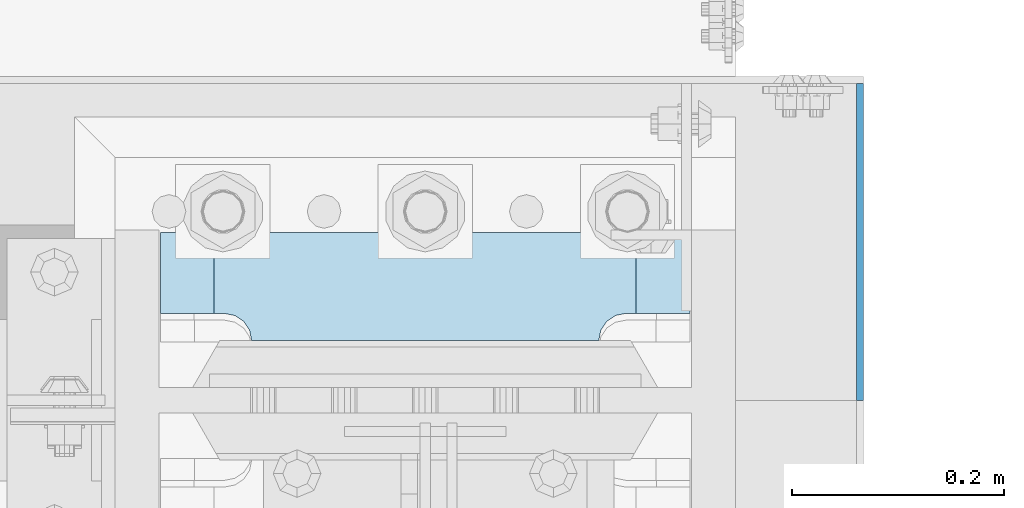
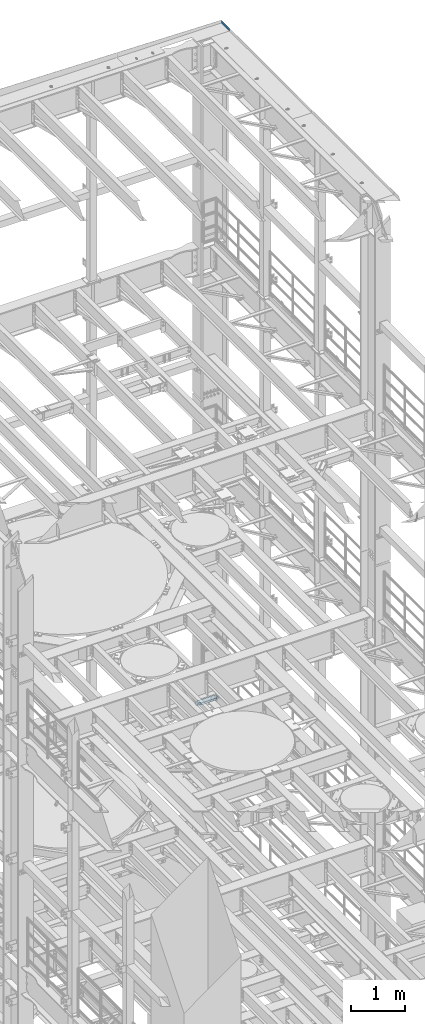
# One storey, part 1826 of 1876: 2 plates, 2 elements without a shape of their own.
"""IFC2X3 building model written with IfcOpenShell, lengths in millimetres."""

from ifc_helpers import new_model, si_unit, frame, origin_with_axes, place, context, subcontext, project, spatial, faceted_brep, material, type_object, element, aggregate, save


model = new_model("IFC2X3")

# Units and contexts
model_context = context("Model", 3, precision=1e-05, world=origin_with_axes())
body_context = subcontext(model_context, "Body", "Model", "MODEL_VIEW")
ifc_project = project(units=[si_unit("LENGTHUNIT", "METRE", prefix="MILLI"), si_unit("AREAUNIT", "SQUARE_METRE"), si_unit("VOLUMEUNIT", "CUBIC_METRE"), si_unit("MASSUNIT", "GRAM", prefix="KILO"), si_unit("TIMEUNIT", "SECOND"), si_unit("PLANEANGLEUNIT", "RADIAN"), si_unit("SOLIDANGLEUNIT", "STERADIAN"), si_unit("THERMODYNAMICTEMPERATUREUNIT", "DEGREE_CELSIUS"), si_unit("LUMINOUSINTENSITYUNIT", "LUMEN")], contexts=[model_context])

# Site, building, storey
site_placement = place(None, origin_with_axes())
site = spatial("IfcSite", under=ifc_project, at=site_placement, CompositionType="ELEMENT")
building_placement = place(site_placement, origin_with_axes())
building = spatial("IfcBuilding", under=site, at=building_placement, Name="Undefined", CompositionType="ELEMENT")
storey_placement = place(building_placement, origin_with_axes())
storey = spatial("IfcBuildingStorey", under=building, at=storey_placement, Name="Undefined", CompositionType="ELEMENT", Elevation=0.0)

# Assembly, plate
assembly_1_placement = place(storey_placement, origin_with_axes())
assembly_1 = element("IfcElementAssembly", 1, at=assembly_1_placement, inside=storey, Name="BENT PLATE", AssemblyPlace="NOTDEFINED", PredefinedType="RIGID_FRAME")
ifc_material_1 = material(Name="STEEL/A36")
plate_type_1 = type_object("IfcPlateType", PredefinedType="NOTDEFINED")
plate_1_placement = place(assembly_1_placement, frame((8029.57470092704, 13716.0000865874, 22561.5174889784), z_axis=(4.95800000044255e-06, 7.19900000513007e-06, 0.999999999961796), x_axis=(0.0, 0.999999999968684, -7.91400000071008e-06)))
plate_1 = element("IfcPlate", 2, at=plate_1_placement, type_object=plate_type_1, material=ifc_material_1, Name="PLATE", context=body_context, shape_type="Brep", body=[
    faceted_brep([(-3.63797880709171e-12, -3.17499999999745, -3.63797880709171e-12), (-0.000774413767430815, -3.17500000001746, 60.3255538939302), (-0.000774413763792836, 3.17499999998017, 60.3255538939375), (3.63797880709171e-12, 3.17499999999836, 3.63797880709171e-12), (298.449523925901, -3.17500000001746, 60.3277206420316), (298.449523925905, 3.17499999998017, 60.3277206420426), (298.449816258273, -3.17500000000382, 19.0499992365294), (298.449816258277, 3.17499999999382, 19.0499992365367), (279.399951934936, -3.17499999999745, -1.81898940354586e-11), (279.39995193494, 3.17499999999836, -1.09139364212751e-11)], [[[0, 1, 2, 3]], [[1, 4, 5, 2]], [[4, 6, 7, 5]], [[6, 8, 9, 7]], [[8, 0, 3, 9]], [[5, 7, 9, 3, 2]], [[8, 6, 4, 1, 0]]]),
])
aggregate(assembly_1, [plate_1])

assembly_2_placement = place(storey_placement, origin_with_axes())
assembly_2 = element("IfcElementAssembly", 3, at=assembly_2_placement, inside=storey, Name="COLUMN", AssemblyPlace="NOTDEFINED", PredefinedType="RIGID_FRAME")
ifc_material_2 = material(Name="STEEL/A572-50")
plate_type_2 = type_object("IfcPlateType", PredefinedType="NOTDEFINED")
plate_2_placement = place(assembly_2_placement, frame((7370.7625, 13772.35625, 7524.75002441406), z_axis=(1.0, 0.0, 0.0), x_axis=(0.0, 1.0, 0.0)))
plate_2 = element("IfcPlate", 4, at=plate_2_placement, type_object=plate_type_2, material=ifc_material_2, Name="PLATE", context=body_context, shape_type="Brep", body=[
    faceted_brep([(101.599998474121, -25.3999999999996, 498.475006103516), (101.599998474121, 25.3999999999996, 447.975004579813), (25.3999996185303, 25.3999999999996, 447.975004579813), (25.3999996185303, -25.3999999999996, 498.475006103516), (23.4665397733534, -25.3999999999996, 428.429848211837), (25.3999996185303, -25.3999999999996, 438.150007247925), (25.3999996185303, 25.3999999999996, 438.150007247925), (23.4665397733534, 25.3999999999996, 428.429848211837), (17.9605119723965, -25.3999999999996, 420.189495275529), (17.9605119723965, 25.3999999999996, 420.189495275529), (9.72015903608917, -25.3999999999996, 414.683467474573), (9.72015903608917, 25.3999999999996, 414.683467474573), (0.0, -25.3999999999996, 412.750007629395), (0.0, 25.3999999999996, 412.750007629395), (0.0, -25.3999999999996, 85.7249984741211), (0.0, 25.3999999999996, 85.7249984741211), (9.72015903609099, -25.3999999999996, 83.7915386289451), (9.72015903609099, 25.3999999999996, 83.7915386289451), (17.9605119723983, -25.3999999999996, 78.2855108279891), (17.9605119723983, 25.3999999999996, 78.2855108279891), (23.4665397733552, -25.3999999999996, 70.0451578916818), (23.4665397733552, 25.3999999999996, 70.0451578916818), (25.3999996185303, -25.3999999999996, 60.3249988555908), (25.3999996185303, 25.3999999999996, 60.3249988555908), (25.3999996185303, 25.3999999999996, 50.5000015237028), (25.3999996185303, -25.3999999999996, 0.0), (101.599998474121, 25.3999999999996, 50.5000015237028), (101.599998474121, -25.3999999999996, 0.0)], [[[0, 1, 2, 3]], [[4, 5, 6, 7]], [[8, 4, 7, 9]], [[10, 8, 9, 11]], [[12, 10, 11, 13]], [[14, 12, 13, 15]], [[16, 14, 15, 17]], [[18, 16, 17, 19]], [[20, 18, 19, 21]], [[22, 20, 21, 23]], [[22, 23, 24, 25]], [[26, 27, 25, 24]], [[5, 4, 8, 10, 12, 14, 16, 18, 20, 22, 25, 27, 0, 3]], [[6, 5, 3, 2]], [[26, 24, 23, 21, 19, 17, 15, 13, 11, 9, 7, 6, 2, 1]], [[27, 26, 1, 0]]]),
])
aggregate(assembly_2, [plate_2])

save(model, "model.ifc")
